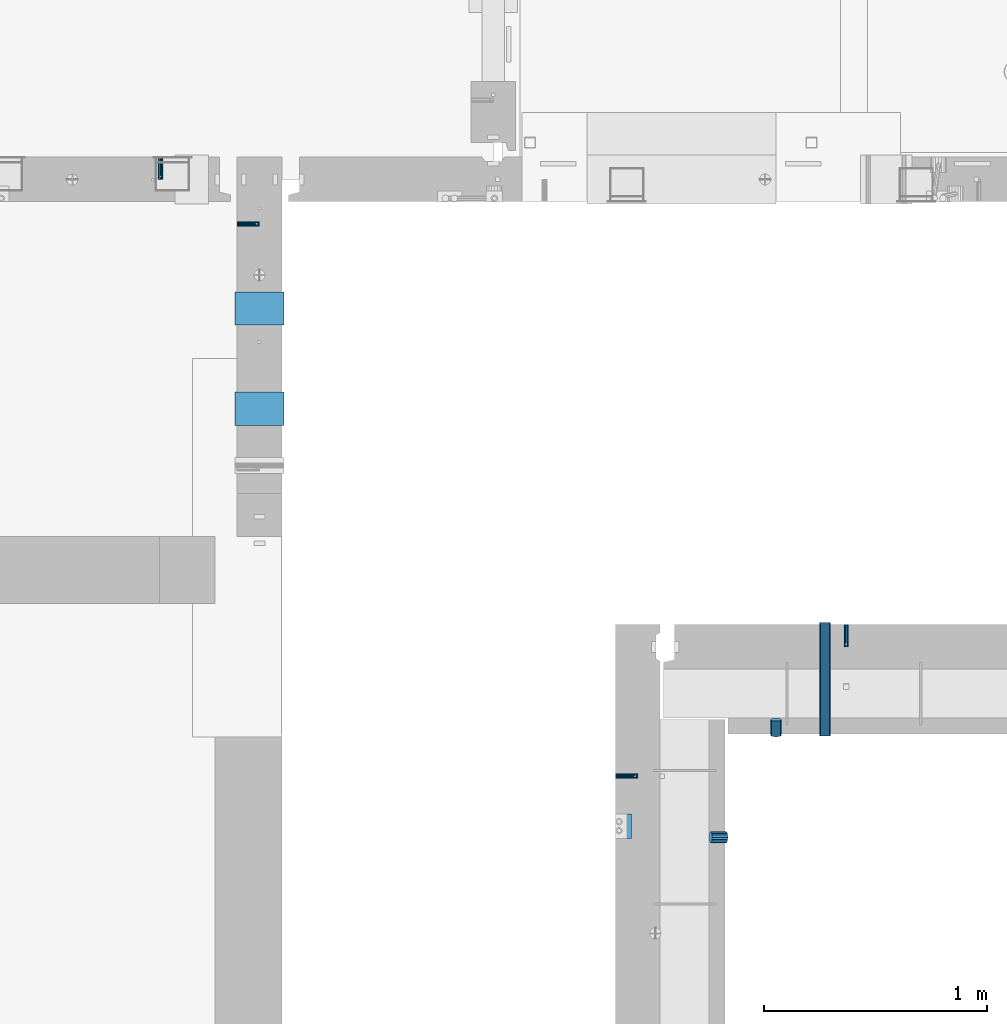
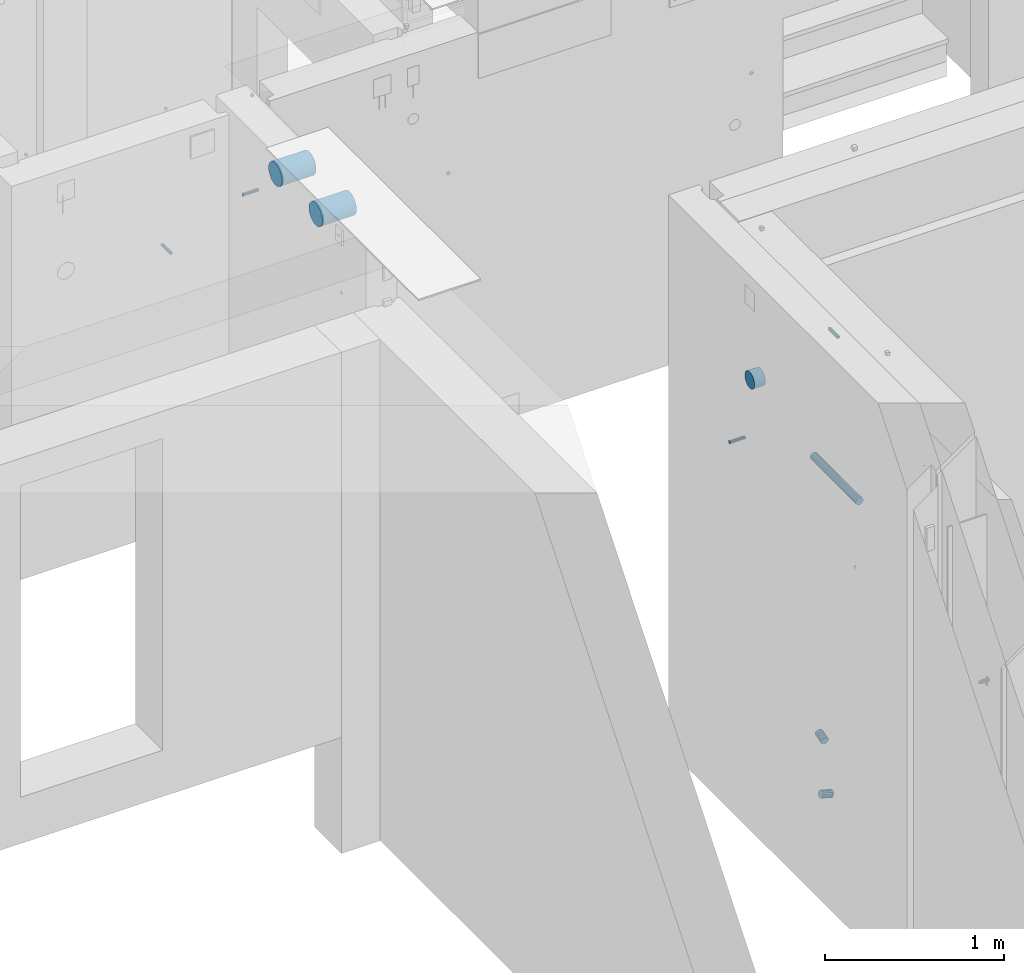
# One storey, part 91 of 264: 10 beams, 13 elements without a shape of their own.
"""IFC2X3 building model written with IfcOpenShell, lengths in millimetres."""

from ifc_helpers import new_model, si_unit, frame, origin_with_axes, place, context, subcontext, project, spatial, faceted_brep, material, type_object, element, aggregate, save


model = new_model("IFC2X3")

# Units and contexts
model_context = context("Model", 3, precision=1e-05, world=origin_with_axes())
body_context = subcontext(model_context, "Body", "Model", "MODEL_VIEW")
ifc_project = project(units=[si_unit("LENGTHUNIT", "METRE", prefix="MILLI"), si_unit("AREAUNIT", "SQUARE_METRE"), si_unit("VOLUMEUNIT", "CUBIC_METRE"), si_unit("MASSUNIT", "GRAM", prefix="KILO"), si_unit("TIMEUNIT", "SECOND"), si_unit("PLANEANGLEUNIT", "RADIAN"), si_unit("SOLIDANGLEUNIT", "STERADIAN"), si_unit("THERMODYNAMICTEMPERATUREUNIT", "DEGREE_CELSIUS"), si_unit("LUMINOUSINTENSITYUNIT", "LUMEN")], contexts=[model_context])

# Site, building, storey
site_placement = place(None, origin_with_axes())
site = spatial("IfcSite", under=ifc_project, at=site_placement, CompositionType="ELEMENT")
building_placement = place(site_placement, origin_with_axes())
building = spatial("IfcBuilding", under=site, at=building_placement, CompositionType="ELEMENT")
storey_placement = place(building_placement, origin_with_axes())
storey = spatial("IfcBuildingStorey", under=building, at=storey_placement, Name="K", CompositionType="ELEMENT", Elevation=0.0)

# Assemblies, beam
assembly_1_placement = place(storey_placement, origin_with_axes())
assembly_1 = element("IfcElementAssembly", 1, at=assembly_1_placement, inside=storey, AssemblyPlace="NOTDEFINED", PredefinedType="REINFORCEMENT_UNIT")
assembly_2_placement = place(assembly_1_placement, origin_with_axes())
assembly_2 = element("IfcElementAssembly", 2, at=assembly_2_placement, Name="Steel Assembly", AssemblyPlace="NOTDEFINED", PredefinedType="RIGID_FRAME")
ifc_material_1 = material(Name="STEEL/Steel_Undefined")
beam_type_1 = type_object("IfcBeamType", PredefinedType="NOTDEFINED")
beam_1_placement = place(assembly_2_placement, frame((18260.0, 12500.0067639291, 80200.0), z_axis=(0.0, 1.0, 0.0), x_axis=(1.0, 0.0, 0.0)))
beam_1 = element("IfcBeam", 3, at=beam_1_placement, type_object=beam_type_1, material=ifc_material_1, Name="M16", context=body_context, shape_type="Brep", body=[
    faceted_brep([(0.0, -8.49999999999272, -1.45519152283669e-11), (0.0, -7.36121593215648, 4.24999999998545), (100.000000000262, -7.36121593215648, 4.24999999998545), (100.000000000262, -8.49999999999272, -1.45519152283669e-11), (0.0, -4.24999999998545, 7.36121593216376), (100.000000000262, -4.24999999998545, 7.36121593216376), (0.0, 1.45519152283669e-11, 8.49999999998545), (100.000000000262, 1.45519152283669e-11, 8.49999999998545), (0.0, 4.25000000001455, 7.36121593216376), (100.000000000262, 4.25000000001455, 7.36121593216376), (0.0, 7.36121593217104, 4.24999999998545), (100.000000000262, 7.36121593217104, 4.24999999998545), (0.0, 8.50000000000728, 0.0), (100.000000000262, 8.50000000000728, 0.0), (0.0, 7.36121593217104, -4.25000000001455), (100.000000000262, 7.36121593217104, -4.25000000001455), (0.0, 4.25000000000728, -7.36121593219286), (100.000000000262, 4.25000000000728, -7.36121593219286), (0.0, 7.27595761418343e-12, -8.5), (100.000000000262, 7.27595761418343e-12, -8.5), (0.0, -4.24999999999272, -7.36121593217831), (100.000000000262, -4.24999999999272, -7.36121593217831), (0.0, -7.36121593215648, -4.25), (100.000000000262, -7.36121593215648, -4.25), (0.0, -10.4999999999927, -1.45519152283669e-11), (0.0, -9.09326673972828, -5.25000000001455), (100.000000000262, -9.09326673972828, -5.25000000001455), (100.000000000262, -10.4999999999927, -1.45519152283669e-11), (0.0, -5.24999999998545, -9.09326673974283), (100.000000000262, -5.24999999998545, -9.09326673974283), (0.0, 7.27595761418343e-12, -10.5), (100.000000000262, 7.27595761418343e-12, -10.5), (0.0, 5.25000000001455, -9.09326673975738), (100.000000000262, 5.25000000001455, -9.09326673975738), (0.0, 9.09326673975011, -5.25000000001455), (100.000000000262, 9.09326673975011, -5.25000000001455), (0.0, 10.5000000000073, -1.45519152283669e-11), (100.000000000262, 10.5000000000073, -1.45519152283669e-11), (0.0, 9.09326673975011, 5.25), (100.000000000262, 9.09326673975011, 5.25), (0.0, 5.25000000000728, 9.09326673972828), (100.000000000262, 5.25000000000728, 9.09326673972828), (0.0, 1.45519152283669e-11, 10.4999999999854), (100.000000000262, 1.45519152283669e-11, 10.4999999999854), (0.0, -5.24999999999272, 9.09326673972828), (100.000000000262, -5.24999999999272, 9.09326673972828), (0.0, -9.09326673972828, 5.24999999998545), (100.000000000262, -9.09326673972828, 5.24999999998545)], [[[0, 1, 2, 3]], [[1, 4, 5, 2]], [[4, 6, 7, 5]], [[6, 8, 9, 7]], [[8, 10, 11, 9]], [[10, 12, 13, 11]], [[12, 14, 15, 13]], [[14, 16, 17, 15]], [[16, 18, 19, 17]], [[18, 20, 21, 19]], [[20, 22, 23, 21]], [[22, 0, 3, 23]], [[24, 25, 26, 27]], [[25, 28, 29, 26]], [[28, 30, 31, 29]], [[30, 32, 33, 31]], [[32, 34, 35, 33]], [[34, 36, 37, 35]], [[36, 38, 39, 37]], [[38, 40, 41, 39]], [[40, 42, 43, 41]], [[42, 44, 45, 43]], [[44, 46, 47, 45]], [[46, 24, 27, 47]], [[29, 31, 33, 35, 37, 39, 41, 43, 45, 47, 27, 26], [5, 7, 9, 11, 13, 15, 17, 19, 21, 23, 3, 2]], [[46, 44, 42, 40, 38, 36, 34, 32, 30, 28, 25, 24], [22, 20, 18, 16, 14, 12, 10, 8, 6, 4, 1, 0]]]),
])
aggregate(assembly_2, [beam_1])

assembly_3_placement = place(storey_placement, origin_with_axes())
assembly_3 = element("IfcElementAssembly", 4, at=assembly_3_placement, inside=storey, AssemblyPlace="NOTDEFINED", PredefinedType="REINFORCEMENT_UNIT")
assembly_4_placement = place(assembly_3_placement, origin_with_axes())
assembly_4 = element("IfcElementAssembly", 5, at=assembly_4_placement, Name="Steel Assembly", AssemblyPlace="NOTDEFINED", PredefinedType="RIGID_FRAME")
beam_2_placement = place(assembly_4_placement, frame((19295.0020037625, 13180.0018965848, 80200.0), z_axis=(-1.0, 3.00000001838171e-08, 0.0), x_axis=(0.0, -1.0, 0.0)))
beam_2 = element("IfcBeam", 6, at=beam_2_placement, type_object=beam_type_1, material=ifc_material_1, Name="M16", context=body_context, shape_type="Brep", body=[
    faceted_brep([(0.0, -8.49999999999272, -1.45519152283669e-11), (0.0, -7.36121593215648, 4.24999999998545), (100.000000000262, -7.36121593215648, 4.24999999998545), (100.000000000262, -8.49999999999272, -1.45519152283669e-11), (0.0, -4.24999999998545, 7.36121593216376), (100.000000000262, -4.24999999998545, 7.36121593216376), (0.0, 1.45519152283669e-11, 8.49999999998545), (100.000000000262, 1.45519152283669e-11, 8.49999999998545), (0.0, 4.25000000001455, 7.36121593216376), (100.000000000262, 4.25000000001455, 7.36121593216376), (0.0, 7.36121593217104, 4.24999999998545), (100.000000000262, 7.36121593217104, 4.24999999998545), (0.0, 8.50000000000728, 0.0), (100.000000000262, 8.50000000000728, 0.0), (0.0, 7.36121593217104, -4.25000000001455), (100.000000000262, 7.36121593217104, -4.25000000001455), (0.0, 4.25000000000728, -7.36121593219286), (100.000000000262, 4.25000000000728, -7.36121593219286), (0.0, 7.27595761418343e-12, -8.5), (100.000000000262, 7.27595761418343e-12, -8.5), (0.0, -4.24999999999272, -7.36121593217831), (100.000000000262, -4.24999999999272, -7.36121593217831), (0.0, -7.36121593215648, -4.25), (100.000000000262, -7.36121593215648, -4.25), (0.0, -10.4999999999927, -1.45519152283669e-11), (0.0, -9.09326673972828, -5.25000000001455), (100.000000000262, -9.09326673972828, -5.25000000001455), (100.000000000262, -10.4999999999927, -1.45519152283669e-11), (0.0, -5.24999999998545, -9.09326673974283), (100.000000000262, -5.24999999998545, -9.09326673974283), (0.0, 7.27595761418343e-12, -10.5), (100.000000000262, 7.27595761418343e-12, -10.5), (0.0, 5.25000000001455, -9.09326673975738), (100.000000000262, 5.25000000001455, -9.09326673975738), (0.0, 9.09326673975011, -5.25000000001455), (100.000000000262, 9.09326673975011, -5.25000000001455), (0.0, 10.5000000000073, -1.45519152283669e-11), (100.000000000262, 10.5000000000073, -1.45519152283669e-11), (0.0, 9.09326673975011, 5.25), (100.000000000262, 9.09326673975011, 5.25), (0.0, 5.25000000000728, 9.09326673972828), (100.000000000262, 5.25000000000728, 9.09326673972828), (0.0, 1.45519152283669e-11, 10.4999999999854), (100.000000000262, 1.45519152283669e-11, 10.4999999999854), (0.0, -5.24999999999272, 9.09326673972828), (100.000000000262, -5.24999999999272, 9.09326673972828), (0.0, -9.09326673972828, 5.24999999998545), (100.000000000262, -9.09326673972828, 5.24999999998545)], [[[0, 1, 2, 3]], [[1, 4, 5, 2]], [[4, 6, 7, 5]], [[6, 8, 9, 7]], [[8, 10, 11, 9]], [[10, 12, 13, 11]], [[12, 14, 15, 13]], [[14, 16, 17, 15]], [[16, 18, 19, 17]], [[18, 20, 21, 19]], [[20, 22, 23, 21]], [[22, 0, 3, 23]], [[24, 25, 26, 27]], [[25, 28, 29, 26]], [[28, 30, 31, 29]], [[30, 32, 33, 31]], [[32, 34, 35, 33]], [[34, 36, 37, 35]], [[36, 38, 39, 37]], [[38, 40, 41, 39]], [[40, 42, 43, 41]], [[42, 44, 45, 43]], [[44, 46, 47, 45]], [[46, 24, 27, 47]], [[29, 31, 33, 35, 37, 39, 41, 43, 45, 47, 27, 26], [5, 7, 9, 11, 13, 15, 17, 19, 21, 23, 3, 2]], [[46, 44, 42, 40, 38, 36, 34, 32, 30, 28, 25, 24], [22, 20, 18, 16, 14, 12, 10, 8, 6, 4, 1, 0]]]),
])
aggregate(assembly_4, [beam_2])

assembly_5_placement = place(storey_placement, origin_with_axes())
assembly_5 = element("IfcElementAssembly", 7, at=assembly_5_placement, inside=storey, AssemblyPlace="NOTDEFINED", PredefinedType="REINFORCEMENT_UNIT")
assembly_6_placement = place(assembly_5_placement, origin_with_axes())
assembly_6 = element("IfcElementAssembly", 8, at=assembly_6_placement, Name="Steel Assembly", AssemblyPlace="NOTDEFINED", PredefinedType="RIGID_FRAME")
aggregate(assembly_5, [assembly_6])
beam_3_placement = place(assembly_6_placement, frame((16559.999999932, 14979.9969487679, 80975.0), z_axis=(0.0, 1.0, 0.0), x_axis=(1.0, 0.0, 0.0)))
beam_3 = element("IfcBeam", 9, at=beam_3_placement, type_object=beam_type_1, material=ifc_material_1, Name="M16", context=body_context, shape_type="Brep", body=[
    faceted_brep([(0.0, -8.49999999999272, -1.45519152283669e-11), (0.0, -7.36121593215648, 4.24999999998545), (100.000000000262, -7.36121593215648, 4.24999999998545), (100.000000000262, -8.49999999999272, -1.45519152283669e-11), (0.0, -4.24999999998545, 7.36121593216376), (100.000000000262, -4.24999999998545, 7.36121593216376), (0.0, 1.45519152283669e-11, 8.49999999998545), (100.000000000262, 1.45519152283669e-11, 8.49999999998545), (0.0, 4.25000000001455, 7.36121593216376), (100.000000000262, 4.25000000001455, 7.36121593216376), (0.0, 7.36121593217104, 4.24999999998545), (100.000000000262, 7.36121593217104, 4.24999999998545), (0.0, 8.50000000000728, 0.0), (100.000000000262, 8.50000000000728, 0.0), (0.0, 7.36121593217104, -4.25000000001455), (100.000000000262, 7.36121593217104, -4.25000000001455), (0.0, 4.25000000000728, -7.36121593219286), (100.000000000262, 4.25000000000728, -7.36121593219286), (0.0, 7.27595761418343e-12, -8.5), (100.000000000262, 7.27595761418343e-12, -8.5), (0.0, -4.24999999999272, -7.36121593217831), (100.000000000262, -4.24999999999272, -7.36121593217831), (0.0, -7.36121593215648, -4.25), (100.000000000262, -7.36121593215648, -4.25), (0.0, -10.4999999999927, -1.45519152283669e-11), (0.0, -9.09326673972828, -5.25000000001455), (100.000000000262, -9.09326673972828, -5.25000000001455), (100.000000000262, -10.4999999999927, -1.45519152283669e-11), (0.0, -5.24999999998545, -9.09326673974283), (100.000000000262, -5.24999999998545, -9.09326673974283), (0.0, 7.27595761418343e-12, -10.5), (100.000000000262, 7.27595761418343e-12, -10.5), (0.0, 5.25000000001455, -9.09326673975738), (100.000000000262, 5.25000000001455, -9.09326673975738), (0.0, 9.09326673975011, -5.25000000001455), (100.000000000262, 9.09326673975011, -5.25000000001455), (0.0, 10.5000000000073, -1.45519152283669e-11), (100.000000000262, 10.5000000000073, -1.45519152283669e-11), (0.0, 9.09326673975011, 5.25), (100.000000000262, 9.09326673975011, 5.25), (0.0, 5.25000000000728, 9.09326673972828), (100.000000000262, 5.25000000000728, 9.09326673972828), (0.0, 1.45519152283669e-11, 10.4999999999854), (100.000000000262, 1.45519152283669e-11, 10.4999999999854), (0.0, -5.24999999999272, 9.09326673972828), (100.000000000262, -5.24999999999272, 9.09326673972828), (0.0, -9.09326673972828, 5.24999999998545), (100.000000000262, -9.09326673972828, 5.24999999998545)], [[[0, 1, 2, 3]], [[1, 4, 5, 2]], [[4, 6, 7, 5]], [[6, 8, 9, 7]], [[8, 10, 11, 9]], [[10, 12, 13, 11]], [[12, 14, 15, 13]], [[14, 16, 17, 15]], [[16, 18, 19, 17]], [[18, 20, 21, 19]], [[20, 22, 23, 21]], [[22, 0, 3, 23]], [[24, 25, 26, 27]], [[25, 28, 29, 26]], [[28, 30, 31, 29]], [[30, 32, 33, 31]], [[32, 34, 35, 33]], [[34, 36, 37, 35]], [[36, 38, 39, 37]], [[38, 40, 41, 39]], [[40, 42, 43, 41]], [[42, 44, 45, 43]], [[44, 46, 47, 45]], [[46, 24, 27, 47]], [[29, 31, 33, 35, 37, 39, 41, 43, 45, 47, 27, 26], [5, 7, 9, 11, 13, 15, 17, 19, 21, 23, 3, 2]], [[46, 44, 42, 40, 38, 36, 34, 32, 30, 28, 25, 24], [22, 20, 18, 16, 14, 12, 10, 8, 6, 4, 1, 0]]]),
])
aggregate(assembly_6, [beam_3])

assembly_7_placement = place(storey_placement, origin_with_axes())
assembly_7 = element("IfcElementAssembly", 10, at=assembly_7_placement, inside=storey, AssemblyPlace="NOTDEFINED", PredefinedType="REINFORCEMENT_UNIT")
assembly_8_placement = place(assembly_7_placement, origin_with_axes())
assembly_8 = element("IfcElementAssembly", 11, at=assembly_8_placement, Name="Steel Assembly", AssemblyPlace="NOTDEFINED", PredefinedType="RIGID_FRAME")
aggregate(assembly_7, [assembly_8])
beam_4_placement = place(assembly_8_placement, frame((16215.0048453855, 15280.0, 80575.0), z_axis=(1.0, 0.0, 0.0), x_axis=(0.0, -1.0, 0.0)))
beam_4 = element("IfcBeam", 12, at=beam_4_placement, type_object=beam_type_1, material=ifc_material_1, Name="M16", context=body_context, shape_type="Brep", body=[
    faceted_brep([(0.0, -8.49999999999272, -1.45519152283669e-11), (0.0, -7.36121593215648, 4.24999999998545), (100.000000000262, -7.36121593215648, 4.24999999998545), (100.000000000262, -8.49999999999272, -1.45519152283669e-11), (0.0, -4.24999999998545, 7.36121593216376), (100.000000000262, -4.24999999998545, 7.36121593216376), (0.0, 1.45519152283669e-11, 8.49999999998545), (100.000000000262, 1.45519152283669e-11, 8.49999999998545), (0.0, 4.25000000001455, 7.36121593216376), (100.000000000262, 4.25000000001455, 7.36121593216376), (0.0, 7.36121593217104, 4.24999999998545), (100.000000000262, 7.36121593217104, 4.24999999998545), (0.0, 8.50000000000728, 0.0), (100.000000000262, 8.50000000000728, 0.0), (0.0, 7.36121593217104, -4.25000000001455), (100.000000000262, 7.36121593217104, -4.25000000001455), (0.0, 4.25000000000728, -7.36121593219286), (100.000000000262, 4.25000000000728, -7.36121593219286), (0.0, 7.27595761418343e-12, -8.5), (100.000000000262, 7.27595761418343e-12, -8.5), (0.0, -4.24999999999272, -7.36121593217831), (100.000000000262, -4.24999999999272, -7.36121593217831), (0.0, -7.36121593215648, -4.25), (100.000000000262, -7.36121593215648, -4.25), (0.0, -10.4999999999927, -1.45519152283669e-11), (0.0, -9.09326673972828, -5.25000000001455), (100.000000000262, -9.09326673972828, -5.25000000001455), (100.000000000262, -10.4999999999927, -1.45519152283669e-11), (0.0, -5.24999999998545, -9.09326673974283), (100.000000000262, -5.24999999998545, -9.09326673974283), (0.0, 7.27595761418343e-12, -10.5), (100.000000000262, 7.27595761418343e-12, -10.5), (0.0, 5.25000000001455, -9.09326673975738), (100.000000000262, 5.25000000001455, -9.09326673975738), (0.0, 9.09326673975011, -5.25000000001455), (100.000000000262, 9.09326673975011, -5.25000000001455), (0.0, 10.5000000000073, -1.45519152283669e-11), (100.000000000262, 10.5000000000073, -1.45519152283669e-11), (0.0, 9.09326673975011, 5.25), (100.000000000262, 9.09326673975011, 5.25), (0.0, 5.25000000000728, 9.09326673972828), (100.000000000262, 5.25000000000728, 9.09326673972828), (0.0, 1.45519152283669e-11, 10.4999999999854), (100.000000000262, 1.45519152283669e-11, 10.4999999999854), (0.0, -5.24999999999272, 9.09326673972828), (100.000000000262, -5.24999999999272, 9.09326673972828), (0.0, -9.09326673972828, 5.24999999998545), (100.000000000262, -9.09326673972828, 5.24999999998545)], [[[0, 1, 2, 3]], [[1, 4, 5, 2]], [[4, 6, 7, 5]], [[6, 8, 9, 7]], [[8, 10, 11, 9]], [[10, 12, 13, 11]], [[12, 14, 15, 13]], [[14, 16, 17, 15]], [[16, 18, 19, 17]], [[18, 20, 21, 19]], [[20, 22, 23, 21]], [[22, 0, 3, 23]], [[24, 25, 26, 27]], [[25, 28, 29, 26]], [[28, 30, 31, 29]], [[30, 32, 33, 31]], [[32, 34, 35, 33]], [[34, 36, 37, 35]], [[36, 38, 39, 37]], [[38, 40, 41, 39]], [[40, 42, 43, 41]], [[42, 44, 45, 43]], [[44, 46, 47, 45]], [[46, 24, 27, 47]], [[29, 31, 33, 35, 37, 39, 41, 43, 45, 47, 27, 26], [5, 7, 9, 11, 13, 15, 17, 19, 21, 23, 3, 2]], [[46, 44, 42, 40, 38, 36, 34, 32, 30, 28, 25, 24], [22, 20, 18, 16, 14, 12, 10, 8, 6, 4, 1, 0]]]),
])
aggregate(assembly_8, [beam_4])

# Beam
ifc_material_2 = material()
beam_type_2 = type_object("IfcBeamType", Name="D110", PredefinedType="NOTDEFINED")
beam_5_placement = place(assembly_1_placement, frame((18260.0, 12275.0003050403, 80760.0), z_axis=(0.0, 0.0, 1.0), x_axis=(1.0, 0.0, 0.0)))
beam_5 = element("IfcBeam", 13, at=beam_5_placement, type_object=beam_type_2, material=ifc_material_2, ObjectType="D110", context=body_context, shape_type="Brep", body=[
    faceted_brep([(0.0, -55.0, 0.0), (0.0, -52.3081083962352, -16.9959346906253), (70.0, -52.3081083962352, -16.9959346906253), (70.0, -55.0, 0.0), (0.0, -44.4959346906217, -32.328188876083), (70.0, -44.4959346906217, -32.328188876083), (0.0, -32.3281888760866, -44.4959346906253), (70.0, -32.3281888760866, -44.4959346906253), (0.0, -16.9959346906217, -52.3081083962315), (70.0, -16.9959346906217, -52.3081083962315), (0.0, 0.0, -55.0), (70.0, 0.0, -55.0), (0.0, 16.9959346906217, -52.3081083962315), (70.0, 16.9959346906217, -52.3081083962315), (0.0, 32.3281888760866, -44.4959346906253), (70.0, 32.3281888760866, -44.4959346906253), (0.0, 44.4959346906217, -32.328188876083), (70.0, 44.4959346906217, -32.328188876083), (0.0, 52.3081083962352, -16.9959346906253), (70.0, 52.3081083962352, -16.9959346906253), (0.0, 55.0, 0.0), (70.0, 55.0, 0.0), (0.0, 52.3081083962352, 16.9959346906253), (70.0, 52.3081083962352, 16.9959346906253), (0.0, 44.4959346906217, 32.328188876083), (70.0, 44.4959346906217, 32.328188876083), (0.0, 32.3281888760866, 44.4959346906253), (70.0, 32.3281888760866, 44.4959346906253), (0.0, 16.9959346906217, 52.3081083962315), (70.0, 16.9959346906217, 52.3081083962315), (0.0, 0.0, 55.0), (70.0, 0.0, 55.0), (0.0, -16.9959346906217, 52.3081083962315), (70.0, -16.9959346906217, 52.3081083962315), (0.0, -32.3281888760866, 44.4959346906253), (70.0, -32.3281888760866, 44.4959346906253), (0.0, -44.4959346906217, 32.328188876083), (70.0, -44.4959346906217, 32.328188876083), (0.0, -52.3081083962352, 16.9959346906253), (70.0, -52.3081083962352, 16.9959346906253)], [[[0, 1, 2, 3]], [[1, 4, 5, 2]], [[4, 6, 7, 5]], [[6, 8, 9, 7]], [[8, 10, 11, 9]], [[10, 12, 13, 11]], [[12, 14, 15, 13]], [[14, 16, 17, 15]], [[16, 18, 19, 17]], [[18, 20, 21, 19]], [[20, 22, 23, 21]], [[22, 24, 25, 23]], [[24, 26, 27, 25]], [[26, 28, 29, 27]], [[28, 30, 31, 29]], [[30, 32, 33, 31]], [[32, 34, 35, 33]], [[34, 36, 37, 35]], [[36, 38, 39, 37]], [[38, 0, 3, 39]], [[5, 7, 9, 11, 13, 15, 17, 19, 21, 23, 25, 27, 29, 31, 33, 35, 37, 39, 3, 2]], [[38, 36, 34, 32, 30, 28, 26, 24, 22, 20, 18, 16, 14, 12, 10, 8, 6, 4, 1, 0]]]),
])

# Assembly, beam
assembly_9_placement = place(storey_placement, origin_with_axes())
assembly_9 = element("IfcElementAssembly", 14, at=assembly_9_placement, inside=storey, Name="Steel Assembly", AssemblyPlace="NOTDEFINED", PredefinedType="NOTDEFINED")
ifc_material_3 = material()
beam_type_3 = type_object("IfcBeamType", Name="D150", PredefinedType="NOTDEFINED")
beam_6_placement = place(assembly_9_placement, frame((16550.0002273917, 14600.0001892447, 81350.0), z_axis=(0.0, 1.0, 0.0), x_axis=(1.0, 0.0, 0.0)))
beam_6 = element("IfcBeam", 15, at=beam_6_placement, type_object=beam_type_3, material=ifc_material_3, ObjectType="D150", context=body_context, shape_type="Brep", body=[
    faceted_brep([(0.0, -75.0, 0.0), (0.0, -72.4444369716803, -19.4114283826893), (219.99885559082, -72.4444369716803, -19.4114283826893), (219.99885559082, -75.0, 0.0), (0.0, -64.9519052838295, -37.5), (219.99885559082, -64.9519052838295, -37.5), (0.0, -53.0330085889873, -53.0330085889909), (219.99885559082, -53.0330085889873, -53.0330085889909), (0.0, -37.5, -64.9519052838332), (219.99885559082, -37.5, -64.9519052838332), (0.0, -19.411428382693, -72.4444369716803), (219.99885559082, -19.411428382693, -72.4444369716803), (0.0, 0.0, -75.0), (219.99885559082, 0.0, -75.0), (0.0, 19.411428382693, -72.4444369716803), (219.99885559082, 19.411428382693, -72.4444369716803), (0.0, 37.5, -64.9519052838332), (219.99885559082, 37.5, -64.9519052838332), (0.0, 53.0330085889873, -53.0330085889909), (219.99885559082, 53.0330085889873, -53.0330085889909), (0.0, 64.9519052838295, -37.5), (219.99885559082, 64.9519052838295, -37.5), (0.0, 72.4444369716803, -19.4114283826893), (219.99885559082, 72.4444369716803, -19.4114283826893), (0.0, 75.0, 0.0), (219.99885559082, 75.0, 0.0), (0.0, 72.4444369716803, 19.4114283826893), (219.99885559082, 72.4444369716803, 19.4114283826893), (0.0, 64.9519052838295, 37.5), (219.99885559082, 64.9519052838295, 37.5), (0.0, 53.0330085889873, 53.0330085889909), (219.99885559082, 53.0330085889873, 53.0330085889909), (0.0, 37.5, 64.9519052838332), (219.99885559082, 37.5, 64.9519052838332), (0.0, 19.411428382693, 72.4444369716803), (219.99885559082, 19.411428382693, 72.4444369716803), (0.0, 0.0, 75.0), (219.99885559082, 0.0, 75.0), (0.0, -19.411428382693, 72.4444369716803), (219.99885559082, -19.411428382693, 72.4444369716803), (0.0, -37.5, 64.9519052838332), (219.99885559082, -37.5, 64.9519052838332), (0.0, -53.0330085889873, 53.0330085889909), (219.99885559082, -53.0330085889873, 53.0330085889909), (0.0, -64.9519052838295, 37.5), (219.99885559082, -64.9519052838295, 37.5), (0.0, -72.4444369716803, 19.4114283826893), (219.99885559082, -72.4444369716803, 19.4114283826893)], [[[0, 1, 2, 3]], [[1, 4, 5, 2]], [[4, 6, 7, 5]], [[6, 8, 9, 7]], [[8, 10, 11, 9]], [[10, 12, 13, 11]], [[12, 14, 15, 13]], [[14, 16, 17, 15]], [[16, 18, 19, 17]], [[18, 20, 21, 19]], [[20, 22, 23, 21]], [[22, 24, 25, 23]], [[24, 26, 27, 25]], [[26, 28, 29, 27]], [[28, 30, 31, 29]], [[30, 32, 33, 31]], [[32, 34, 35, 33]], [[34, 36, 37, 35]], [[36, 38, 39, 37]], [[38, 40, 41, 39]], [[40, 42, 43, 41]], [[42, 44, 45, 43]], [[44, 46, 47, 45]], [[46, 0, 3, 47]], [[5, 7, 9, 11, 13, 15, 17, 19, 21, 23, 25, 27, 29, 31, 33, 35, 37, 39, 41, 43, 45, 47, 3, 2]], [[46, 44, 42, 40, 38, 36, 34, 32, 30, 28, 26, 24, 22, 20, 18, 16, 14, 12, 10, 8, 6, 4, 1, 0]]]),
])
aggregate(assembly_9, [beam_6])

assembly_10_placement = place(storey_placement, origin_with_axes())
assembly_10 = element("IfcElementAssembly", 16, at=assembly_10_placement, inside=storey, Name="Steel Assembly", AssemblyPlace="NOTDEFINED", PredefinedType="NOTDEFINED")
beam_7_placement = place(assembly_10_placement, frame((16550.0002273917, 14150.0003799796, 81350.0), z_axis=(0.0, 1.0, 0.0), x_axis=(1.0, 0.0, 0.0)))
beam_7 = element("IfcBeam", 17, at=beam_7_placement, type_object=beam_type_3, material=ifc_material_3, ObjectType="D150", context=body_context, shape_type="Brep", body=[
    faceted_brep([(0.0, -75.0, 0.0), (0.0, -72.4444369716803, -19.4114283826893), (219.79619956727, -72.4444369716803, -19.4114283826893), (219.79619956727, -75.0, 0.0), (0.0, -64.9519052838295, -37.5), (219.79619956727, -64.9519052838295, -37.5), (0.0, -53.0330085889873, -53.0330085889909), (219.79619956727, -53.0330085889873, -53.0330085889909), (0.0, -37.5, -64.9519052838332), (219.79619956727, -37.5, -64.9519052838332), (0.0, -19.411428382693, -72.4444369716803), (219.79619956727, -19.411428382693, -72.4444369716803), (0.0, 0.0, -75.0), (219.79619956727, 0.0, -75.0), (0.0, 19.411428382693, -72.4444369716803), (219.79619956727, 19.411428382693, -72.4444369716803), (0.0, 37.5, -64.9519052838332), (219.79619956727, 37.5, -64.9519052838332), (0.0, 53.0330085889873, -53.0330085889909), (219.79619956727, 53.0330085889873, -53.0330085889909), (0.0, 64.9519052838295, -37.5), (219.79619956727, 64.9519052838295, -37.5), (0.0, 72.4444369716803, -19.4114283826893), (219.79619956727, 72.4444369716803, -19.4114283826893), (0.0, 75.0, 0.0), (219.79619956727, 75.0, 0.0), (0.0, 72.4444369716803, 19.4114283826893), (219.79619956727, 72.4444369716803, 19.4114283826893), (0.0, 64.9519052838295, 37.5), (219.79619956727, 64.9519052838295, 37.5), (0.0, 53.0330085889873, 53.0330085889909), (219.79619956727, 53.0330085889873, 53.0330085889909), (0.0, 37.5, 64.9519052838332), (219.79619956727, 37.5, 64.9519052838332), (0.0, 19.411428382693, 72.4444369716803), (219.79619956727, 19.411428382693, 72.4444369716803), (0.0, 0.0, 75.0), (219.79619956727, 0.0, 75.0), (0.0, -19.411428382693, 72.4444369716803), (219.79619956727, -19.411428382693, 72.4444369716803), (0.0, -37.5, 64.9519052838332), (219.79619956727, -37.5, 64.9519052838332), (0.0, -53.0330085889873, 53.0330085889909), (219.79619956727, -53.0330085889873, 53.0330085889909), (0.0, -64.9519052838295, 37.5), (219.79619956727, -64.9519052838295, 37.5), (0.0, -72.4444369716803, 19.4114283826893), (219.79619956727, -72.4444369716803, 19.4114283826893)], [[[0, 1, 2, 3]], [[1, 4, 5, 2]], [[4, 6, 7, 5]], [[6, 8, 9, 7]], [[8, 10, 11, 9]], [[10, 12, 13, 11]], [[12, 14, 15, 13]], [[14, 16, 17, 15]], [[16, 18, 19, 17]], [[18, 20, 21, 19]], [[20, 22, 23, 21]], [[22, 24, 25, 23]], [[24, 26, 27, 25]], [[26, 28, 29, 27]], [[28, 30, 31, 29]], [[30, 32, 33, 31]], [[32, 34, 35, 33]], [[34, 36, 37, 35]], [[36, 38, 39, 37]], [[38, 40, 41, 39]], [[40, 42, 43, 41]], [[42, 44, 45, 43]], [[44, 46, 47, 45]], [[46, 0, 3, 47]], [[5, 7, 9, 11, 13, 15, 17, 19, 21, 23, 25, 27, 29, 31, 33, 35, 37, 39, 41, 43, 45, 47, 3, 2]], [[46, 44, 42, 40, 38, 36, 34, 32, 30, 28, 26, 24, 22, 20, 18, 16, 14, 12, 10, 8, 6, 4, 1, 0]]]),
])
aggregate(assembly_10, [beam_7])

assembly_11_placement = place(storey_placement, origin_with_axes())
assembly_11 = element("IfcElementAssembly", 18, at=assembly_11_placement, inside=storey, Name="Steel Assembly", AssemblyPlace="NOTDEFINED", PredefinedType="NOTDEFINED")
beam_type_4 = type_object("IfcBeamType", Name="D50", PredefinedType="NOTDEFINED")
beam_8_placement = place(assembly_11_placement, frame((19200.4440292716, 12680.0003418326, 79360.0), z_axis=(0.0, 0.0, 1.0), x_axis=(0.0, 1.0, 0.0)))
beam_8 = element("IfcBeam", 19, at=beam_8_placement, type_object=beam_type_4, material=ifc_material_3, ObjectType="D50", context=body_context, shape_type="Brep", body=[
    faceted_brep([(0.0, -25.0, 0.0), (-3.63797880709171e-12, -23.0969883127837, -9.56708580912891), (509.999457127145, -23.0969883127837, -9.56708580913255), (509.999457127145, -25.0, 0.0), (-3.63797880709171e-12, -17.6776695296576, -17.6776695296649), (509.999457127145, -17.6776695296649, -17.6776695296576), (-1.09139364212751e-11, -9.56708580913255, -23.0969883127837), (509.999457127145, -9.56708580912891, -23.0969883127837), (-1.09139364212751e-11, 0.0, -25.0), (509.999457127145, 0.0, -25.0), (-1.09139364212751e-11, 9.56708580913255, -23.0969883127837), (509.999457127145, 9.56708580912891, -23.0969883127837), (-3.63797880709171e-12, 17.6776695296576, -17.6776695296649), (509.999457127145, 17.6776695296649, -17.6776695296576), (-3.63797880709171e-12, 23.0969883127837, -9.56708580912891), (509.999457127145, 23.0969883127837, -9.56708580913255), (0.0, 25.0, 0.0), (509.999457127145, 25.0, 0.0), (7.27595761418343e-12, 23.0969883127837, 9.56708580912891), (509.999457127145, 23.0969883127837, 9.56708580913255), (7.27595761418343e-12, 17.6776695296576, 17.6776695296649), (509.999457127145, 17.6776695296649, 17.6776695296576), (1.45519152283669e-11, 9.56708580913255, 23.0969883127837), (509.999457127145, 9.56708580912891, 23.0969883127837), (1.09139364212751e-11, 0.0, 25.0), (509.999457127145, 0.0, 25.0), (1.45519152283669e-11, -9.56708580913255, 23.0969883127837), (509.999457127145, -9.56708580912891, 23.0969883127837), (7.27595761418343e-12, -17.6776695296576, 17.6776695296649), (509.999457127145, -17.6776695296649, 17.6776695296576), (7.27595761418343e-12, -23.0969883127837, 9.56708580912891), (509.999457127145, -23.0969883127837, 9.56708580913255)], [[[0, 1, 2, 3]], [[1, 4, 5, 2]], [[4, 6, 7, 5]], [[6, 8, 9, 7]], [[8, 10, 11, 9]], [[10, 12, 13, 11]], [[12, 14, 15, 13]], [[14, 16, 17, 15]], [[16, 18, 19, 17]], [[18, 20, 21, 19]], [[20, 22, 23, 21]], [[22, 24, 25, 23]], [[24, 26, 27, 25]], [[26, 28, 29, 27]], [[28, 30, 31, 29]], [[30, 0, 3, 31]], [[5, 7, 9, 11, 13, 15, 17, 19, 21, 23, 25, 27, 29, 31, 3, 2]], [[30, 28, 26, 24, 22, 20, 18, 16, 14, 12, 10, 8, 6, 4, 1, 0]]]),
])
aggregate(assembly_11, [beam_8])

# Assembly
assembly_12_placement = place(assembly_1_placement, origin_with_axes())
assembly_12 = element("IfcElementAssembly", 20, at=assembly_12_placement, Name="Steel Assembly", AssemblyPlace="NOTDEFINED", PredefinedType="NOTDEFINED")

aggregate(assembly_1, [beam_5, assembly_2, assembly_12])

# Beam
ifc_material_4 = material()
beam_9_placement = place(assembly_12_placement, frame((18686.8680281974, 12225.0018965848, 77824.0380986929), z_axis=(0.0, 1.0, 0.0), x_axis=(0.961523947640827, 0.0, -0.274721127897365)))
beam_9 = element("IfcBeam", 21, at=beam_9_placement, type_object=beam_type_4, material=ifc_material_4, ObjectType="D50", context=body_context, shape_type="Brep", body=[
    faceted_brep([(0.0, -25.0, 0.0), (-3.63797880709171e-12, -23.0969883127837, -9.56708580912891), (72.8010988927999, -23.0969883127982, -9.56708580912891), (72.8010988927999, -25.0, 0.0), (-3.63797880709171e-12, -17.6776695296576, -17.6776695296649), (72.8010988927927, -17.6776695296576, -17.6776695296649), (-1.09139364212751e-11, -9.56708580913255, -23.0969883127837), (72.8010988927927, -9.56708580913255, -23.0969883127837), (-1.09139364212751e-11, 0.0, -25.0), (72.8010988927927, 0.0, -25.0), (-1.09139364212751e-11, 9.56708580913255, -23.0969883127837), (72.8010988927999, 9.56708580913255, -23.0969883127837), (-3.63797880709171e-12, 17.6776695296576, -17.6776695296649), (72.8010988927999, 17.6776695296721, -17.6776695296649), (-3.63797880709171e-12, 23.0969883127837, -9.56708580912891), (72.8010988927999, 23.0969883127837, -9.56708580912891), (0.0, 25.0, 0.0), (72.8010988927999, 25.0, 0.0), (7.27595761418343e-12, 23.0969883127837, 9.56708580912891), (72.8010988927999, 23.0969883127837, 9.56708580912891), (7.27595761418343e-12, 17.6776695296576, 17.6776695296649), (72.8010988927999, 17.6776695296721, 17.6776695296649), (1.45519152283669e-11, 9.56708580913255, 23.0969883127837), (72.8010988927999, 9.56708580913255, 23.0969883127837), (1.09139364212751e-11, 0.0, 25.0), (72.8010988927927, 0.0, 25.0), (1.45519152283669e-11, -9.56708580913255, 23.0969883127837), (72.8010988927927, -9.56708580913255, 23.0969883127837), (7.27595761418343e-12, -17.6776695296576, 17.6776695296649), (72.8010988927927, -17.6776695296576, 17.6776695296649), (7.27595761418343e-12, -23.0969883127837, 9.56708580912891), (72.8010988927999, -23.0969883127982, 9.56708580912891)], [[[0, 1, 2, 3]], [[1, 4, 5, 2]], [[4, 6, 7, 5]], [[6, 8, 9, 7]], [[8, 10, 11, 9]], [[10, 12, 13, 11]], [[12, 14, 15, 13]], [[14, 16, 17, 15]], [[16, 18, 19, 17]], [[18, 20, 21, 19]], [[20, 22, 23, 21]], [[22, 24, 25, 23]], [[24, 26, 27, 25]], [[26, 28, 29, 27]], [[28, 30, 31, 29]], [[30, 0, 3, 31]], [[5, 7, 9, 11, 13, 15, 17, 19, 21, 23, 25, 27, 29, 31, 3, 2]], [[30, 28, 26, 24, 22, 20, 18, 16, 14, 12, 10, 8, 6, 4, 1, 0]]]),
])

aggregate(assembly_12, [beam_9])

# Assembly
assembly_13_placement = place(assembly_3_placement, origin_with_axes())
assembly_13 = element("IfcElementAssembly", 22, at=assembly_13_placement, Name="Steel Assembly", AssemblyPlace="NOTDEFINED", PredefinedType="NOTDEFINED")

aggregate(assembly_3, [assembly_4, assembly_13])

# Beam
beam_10_placement = place(assembly_13_placement, frame((18980.0, 12753.1338683873, 77824.0380986929), z_axis=(1.0, 0.0, 0.0), x_axis=(0.0, -0.96152394764082, -0.274721127897391)))
beam_10 = element("IfcBeam", 23, at=beam_10_placement, type_object=beam_type_4, material=ifc_material_4, ObjectType="D50", context=body_context, shape_type="Brep", body=[
    faceted_brep([(0.0, -25.0, 0.0), (-3.63797880709171e-12, -23.0969883127837, -9.56708580912891), (72.8010988927999, -23.0969883127982, -9.56708580912891), (72.8010988927999, -25.0, 0.0), (-3.63797880709171e-12, -17.6776695296576, -17.6776695296649), (72.8010988927927, -17.6776695296576, -17.6776695296649), (-1.09139364212751e-11, -9.56708580913255, -23.0969883127837), (72.8010988927927, -9.56708580913255, -23.0969883127837), (-1.09139364212751e-11, 0.0, -25.0), (72.8010988927927, 0.0, -25.0), (-1.09139364212751e-11, 9.56708580913255, -23.0969883127837), (72.8010988927999, 9.56708580913255, -23.0969883127837), (-3.63797880709171e-12, 17.6776695296576, -17.6776695296649), (72.8010988927999, 17.6776695296721, -17.6776695296649), (-3.63797880709171e-12, 23.0969883127837, -9.56708580912891), (72.8010988927999, 23.0969883127837, -9.56708580912891), (0.0, 25.0, 0.0), (72.8010988927999, 25.0, 0.0), (7.27595761418343e-12, 23.0969883127837, 9.56708580912891), (72.8010988927999, 23.0969883127837, 9.56708580912891), (7.27595761418343e-12, 17.6776695296576, 17.6776695296649), (72.8010988927999, 17.6776695296721, 17.6776695296649), (1.45519152283669e-11, 9.56708580913255, 23.0969883127837), (72.8010988927999, 9.56708580913255, 23.0969883127837), (1.09139364212751e-11, 0.0, 25.0), (72.8010988927927, 0.0, 25.0), (1.45519152283669e-11, -9.56708580913255, 23.0969883127837), (72.8010988927927, -9.56708580913255, 23.0969883127837), (7.27595761418343e-12, -17.6776695296576, 17.6776695296649), (72.8010988927927, -17.6776695296576, 17.6776695296649), (7.27595761418343e-12, -23.0969883127837, 9.56708580912891), (72.8010988927999, -23.0969883127982, 9.56708580912891)], [[[0, 1, 2, 3]], [[1, 4, 5, 2]], [[4, 6, 7, 5]], [[6, 8, 9, 7]], [[8, 10, 11, 9]], [[10, 12, 13, 11]], [[12, 14, 15, 13]], [[14, 16, 17, 15]], [[16, 18, 19, 17]], [[18, 20, 21, 19]], [[20, 22, 23, 21]], [[22, 24, 25, 23]], [[24, 26, 27, 25]], [[26, 28, 29, 27]], [[28, 30, 31, 29]], [[30, 0, 3, 31]], [[5, 7, 9, 11, 13, 15, 17, 19, 21, 23, 25, 27, 29, 31, 3, 2]], [[30, 28, 26, 24, 22, 20, 18, 16, 14, 12, 10, 8, 6, 4, 1, 0]]]),
])

aggregate(assembly_13, [beam_10])

save(model, "model.ifc")
